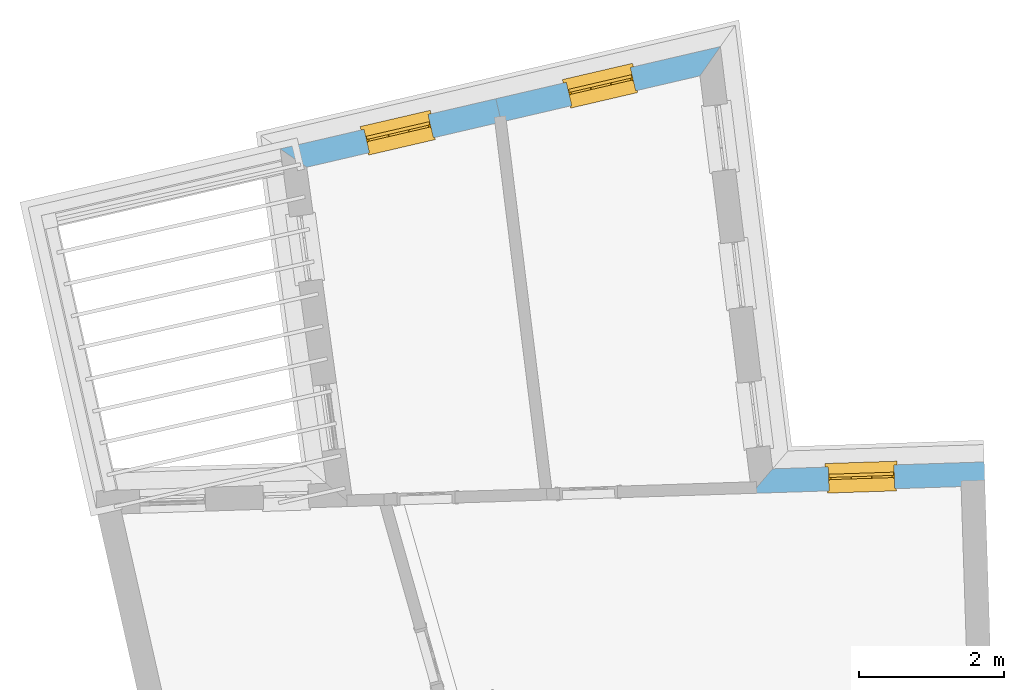
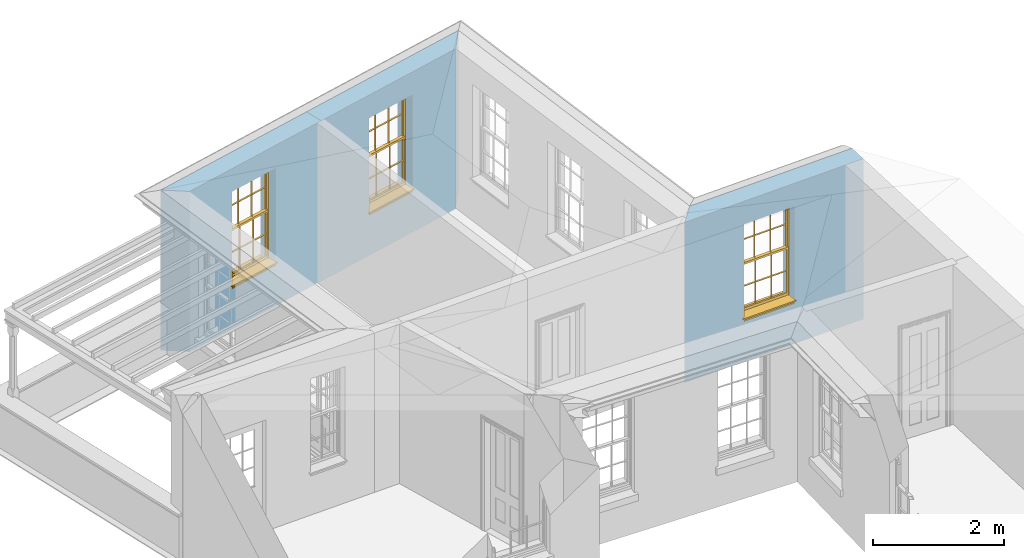
# One storey, part 8 of 11: 3 windows, 3 openings, plus 3 elements that do not belong to this part.
"""IFC2X3 building model written with IfcOpenShell, lengths in metres."""

import ifcopenshell
import ifcopenshell.guid

model = None  # the IFC model being written
_history = None  # IfcOwnerHistory: only IFC2X3 demands one
_inside = {}  # id of a spatial element -> (the spatial element, [elements in it])
_under = {}  # id of a project, library or spatial element -> (it, [spatial elements below it])
_declared = {}  # id of a project -> (the project, [libraries it declares])
_typed = {}  # id of a type object -> (the type object, [elements of that type])
_made_of = {}  # id of a material, layer set ... -> (it, [elements and type objects made of it])


def new_model(schema):
    """Start an empty IFC model of exactly this schema.

    Asked for "IFC4X3", IfcOpenShell would pick the latest addendum, in which some entities
    have other attributes; the version numbers below select the first issue.
    IFC2X3 requires an IfcOwnerHistory on every rooted entity: one is made here for all.
    """
    global model, _history
    if schema == "IFC4X3":
        model = ifcopenshell.file(schema_version=(4, 3, 0, 0))
    else:
        model = ifcopenshell.file(schema=schema)
    _inside.clear()
    _under.clear()
    _declared.clear()
    _typed.clear()
    _made_of.clear()
    _history = None
    if model.schema == "IFC2X3":
        org = make("IfcOrganization", Name="unknown")
        user = make(
            "IfcPersonAndOrganization",
            ThePerson=make("IfcPerson", FamilyName="unknown"),
            TheOrganization=org,
        )
        app = make(
            "IfcApplication",
            ApplicationDeveloper=org,
            Version="unknown",
            ApplicationFullName="unknown",
            ApplicationIdentifier="unknown",
        )
        _history = make(
            "IfcOwnerHistory",
            OwningUser=user,
            OwningApplication=app,
            ChangeAction="ADDED",
            CreationDate=0,
        )
    return model


def make(cls, **values):
    """One entity of the class cls with the attributes given. An attribute that is None is left unset."""
    return model.create_entity(
        cls, **{name: value for name, value in values.items() if value is not None}
    )


def rooted(cls, **values):
    """An entity with a GlobalId (a new one), such as an element, a storey or a relation."""
    return make(cls, GlobalId=ifcopenshell.guid.new(), OwnerHistory=_history, **values)


def si_unit(unit_type, name, prefix=None):
    """IfcSIUnit, for example si_unit("LENGTHUNIT", "METRE", prefix="MILLI")."""
    return make("IfcSIUnit", UnitType=unit_type, Prefix=prefix, Name=name)


def assignment(units):
    """IfcUnitAssignment: the units of a project."""
    return None if units is None else make("IfcUnitAssignment", Units=units)


def point(xyz):
    """IfcCartesianPoint."""
    return None if xyz is None else make("IfcCartesianPoint", Coordinates=xyz)


def direction(xyz):
    """IfcDirection."""
    return None if xyz is None else make("IfcDirection", DirectionRatios=xyz)


def frame(location, z_axis=None, x_axis=None):
    """IfcAxis2Placement3D, a coordinate frame: its origin and axes. An axis left out is left unset."""
    return make(
        "IfcAxis2Placement3D",
        Location=point(location),
        Axis=direction(z_axis),
        RefDirection=direction(x_axis),
    )


def origin():
    """The frame at (0, 0, 0) with its axes left unset."""
    return frame((0.0, 0.0, 0.0))


def place(relative_to, where):
    """IfcLocalPlacement: puts the frame where relative to a parent placement (None: the world)."""
    return make(
        "IfcLocalPlacement", PlacementRelTo=relative_to, RelativePlacement=where
    )


def context(
    kind, dimensions, precision=None, world=None, true_north=None, identifier=None
):
    """IfcGeometricRepresentationContext, for example the 3D "Model" context."""
    return make(
        "IfcGeometricRepresentationContext",
        ContextIdentifier=identifier,
        ContextType=kind,
        CoordinateSpaceDimension=dimensions,
        Precision=precision,
        WorldCoordinateSystem=world,
        TrueNorth=true_north,
    )


def subcontext(parent, identifier, kind, view, scale=None):
    """IfcGeometricRepresentationSubContext, for example "Body" below "Model"."""
    return make(
        "IfcGeometricRepresentationSubContext",
        ContextIdentifier=identifier,
        ContextType=kind,
        ParentContext=parent,
        TargetScale=scale,
        TargetView=view,
    )


def project(units=None, contexts=None):
    """IfcProject with its units and contexts."""
    return rooted(
        "IfcProject",
        Name="project",
        RepresentationContexts=contexts,
        UnitsInContext=assignment(units),
    )


def spatial(cls, under=None, at=None, **own):
    """A site, building, storey or space (cls), placed at a placement, below another one or the project."""
    s = rooted(cls, ObjectPlacement=at, **own)
    if under is not None:
        _under.setdefault(under.id(), (under, []))[1].append(s)
    return s


def polyline(points):
    """IfcPolyline through the points."""
    return make("IfcPolyline", Points=[point(p) for p in points])


def outline(outer, holes=None, kind="AREA"):
    """IfcArbitraryClosedProfileDef: a profile drawn as a closed curve; with holes, ...WithVoids."""
    if holes is None:
        return make("IfcArbitraryClosedProfileDef", ProfileType=kind, OuterCurve=outer)
    return make(
        "IfcArbitraryProfileDefWithVoids",
        ProfileType=kind,
        OuterCurve=outer,
        InnerCurves=holes,
    )


def extrude(swept, where, along, depth):
    """IfcExtrudedAreaSolid: the profile swept, set in the frame where, extruded along a direction by depth."""
    return make(
        "IfcExtrudedAreaSolid",
        SweptArea=swept,
        Position=where,
        ExtrudedDirection=direction(along),
        Depth=depth,
    )


def faces_of(points, faces, orient=None, outer=None):
    """IfcFace entities. A face is a list of loops; a loop is a list of indices into points, from 0.

    orient and outer hold one flag for each loop. By default every Orientation is true, the
    first loop of a face is its IfcFaceOuterBound and the others are IfcFaceBound.
    """
    made = []
    for i, loops in enumerate(faces):
        bounds = []
        for j, loop in enumerate(loops):
            is_outer = j == 0 if outer is None else outer[i][j]
            bounds.append(
                make(
                    "IfcFaceOuterBound" if is_outer else "IfcFaceBound",
                    Bound=make("IfcPolyLoop", Polygon=[points[k] for k in loop]),
                    Orientation=True if orient is None else orient[i][j],
                )
            )
        made.append(make("IfcFace", Bounds=bounds))
    return made


def faceted_brep(points, faces, orient=None, outer=None, voids=None):
    """IfcFacetedBrep: a solid bounded by flat faces; with voids (closed shells), ...WithVoids."""
    shared = [point(p) for p in points]
    hull = make("IfcClosedShell", CfsFaces=faces_of(shared, faces, orient, outer))
    if voids is None:
        return make("IfcFacetedBrep", Outer=hull)
    return make(
        "IfcFacetedBrepWithVoids",
        Outer=hull,
        Voids=[
            make(cls, CfsFaces=faces_of(shared, fs, o, b)) for cls, fs, o, b in voids
        ],
    )


def shape(context_of_items, identifier, shape_type, items):
    """IfcShapeRepresentation: the items that make up one representation, for example the "Body"."""
    return make(
        "IfcShapeRepresentation",
        ContextOfItems=context_of_items,
        RepresentationIdentifier=identifier,
        RepresentationType=shape_type,
        Items=items,
    )


def material(Name=None, Category=None):
    """IfcMaterial."""
    return make("IfcMaterial", Name=Name, Category=Category)


def layer(
    of_material, thickness, ventilated=None, Name=None, Category=None, Priority=None
):
    """IfcMaterialLayer: one layer of a wall or slab, of a material (None: an air gap)."""
    return make(
        "IfcMaterialLayer",
        Material=of_material,
        LayerThickness=thickness,
        IsVentilated=ventilated,
        Name=Name,
        Category=Category,
        Priority=Priority,
    )


def layer_set(layers, Name=None):
    """IfcMaterialLayerSet."""
    return make("IfcMaterialLayerSet", MaterialLayers=layers, LayerSetName=Name)


def layer_usage(for_layer_set, set_direction, sense, offset, extent=None):
    """IfcMaterialLayerSetUsage: how a layer set lies in its element."""
    return make(
        "IfcMaterialLayerSetUsage",
        ForLayerSet=for_layer_set,
        LayerSetDirection=set_direction,
        DirectionSense=sense,
        OffsetFromReferenceLine=offset,
        ReferenceExtent=extent,
    )


def made_of(thing, what):
    """Note that an element or type object is made of a material, layer set ...; save() writes the relation."""
    if what is not None:
        _made_of.setdefault(what.id(), (what, []))[1].append(thing)
    return thing


def element(
    cls,
    number,
    at=None,
    inside=None,
    cuts=None,
    type_object=None,
    material=None,
    context=None,
    identifier="Body",
    shape_type=None,
    held_by="IfcProductDefinitionShape",
    body=None,
    shapes=None,
    **own,
):
    """One element of the class cls, such as IfcWall. Its Tag is "e" and its number.

    at: its placement. inside: the storey or other place that contains it. cuts: it is an
    opening in that element (IfcRelVoidsElement). A single representation is given by context,
    identifier, shape_type and body (its items); several are given by shapes. held_by: the class
    of the entity that holds the representations. save() writes the other relations.
    """
    e = rooted(cls, Tag="e%d" % number, ObjectPlacement=at, **own)
    if body is not None:
        shapes = [shape(context, identifier, shape_type, body)]
    if shapes is not None:
        e.Representation = make(held_by, Representations=shapes)
    if inside is not None:
        _inside.setdefault(inside.id(), (inside, []))[1].append(e)
    if cuts is not None:
        rooted(
            "IfcRelVoidsElement", RelatingBuildingElement=cuts, RelatedOpeningElement=e
        )
    if type_object is not None:
        _typed.setdefault(type_object.id(), (type_object, []))[1].append(e)
    return made_of(e, material)


def fill(opening, filler):
    """IfcRelFillsElement: the door or window that sits in an opening."""
    return rooted(
        "IfcRelFillsElement",
        RelatingOpeningElement=opening,
        RelatedBuildingElement=filler,
    )


def aggregate(whole, parts):
    """IfcRelAggregates: a whole, such as a stair, and the parts it consists of."""
    return rooted("IfcRelAggregates", RelatingObject=whole, RelatedObjects=parts)


def save(model, path):
    """Write the relations noted so far, then the file.

    IfcRelAggregates (storeys below a building ...), IfcRelContainedInSpatialStructure (elements
    in a storey), IfcRelDefinesByType, IfcRelAssociatesMaterial and IfcRelDeclares: one each for
    every whole, place, type object, material and project.
    """
    for whole, parts in _under.values():
        aggregate(whole, parts)
    for where, things in _inside.values():
        rooted(
            "IfcRelContainedInSpatialStructure",
            RelatedElements=things,
            RelatingStructure=where,
        )
    for kind, things in _typed.values():
        rooted("IfcRelDefinesByType", RelatedObjects=things, RelatingType=kind)
    for what, things in _made_of.values():
        rooted("IfcRelAssociatesMaterial", RelatedObjects=things, RelatingMaterial=what)
    for by, libraries in _declared.values():
        rooted("IfcRelDeclares", RelatingContext=by, RelatedDefinitions=libraries)
    model.write(path)


model = new_model("IFC2X3")

# Units and contexts
model_context = context("Model", 3, world=origin())
body_context = subcontext(model_context, "Body", "Model", "MODEL_VIEW")
ifc_project = project(units=[si_unit("PLANEANGLEUNIT", "RADIAN"), si_unit("MASSUNIT", "GRAM", prefix="KILO"), si_unit("FORCEUNIT", "NEWTON", prefix="KILO"), si_unit("LENGTHUNIT", "METRE")], contexts=[model_context])

# Site, building, storey
site_placement = place(None, origin())
site = spatial("IfcSite", under=ifc_project, at=site_placement, CompositionType="ELEMENT")
building_placement = place(None, origin())
building = spatial("IfcBuilding", under=site, at=building_placement, Name="Building plot-10", CompositionType="ELEMENT")
storey_placement = place(None, frame((0.0, 0.0, 4.6)))
storey = spatial("IfcBuildingStorey", under=building, at=storey_placement, Name="Floor 1", CompositionType="ELEMENT", Elevation=4.6)

# Wall, opening, window
ifc_material = material(Name="Masonry")
ifc_layer = layer(ifc_material, 0.33, ventilated=False)
ifc_layer_set = layer_set([ifc_layer], Name="My Wall")
ifc_layer_usage = layer_usage(ifc_layer_set, "AXIS2", "NEGATIVE", 0.08)
wall_1_placement = place(storey_placement, origin())
wall_1 = element("IfcWallStandardCase", 1, at=wall_1_placement, inside=storey, material=ifc_layer_usage, Name="exterior", context=body_context, shape_type="SweptSolid", body=[
    extrude(outline(polyline([(53.7197932357243, 20.1894345087971), (53.7090479718279, 20.5192595219538), (50.7843534970595, 20.4239768335759), (50.4938484504191, 20.0843374826447), (53.7197932357243, 20.1894345087971)])), origin(), (0.0, 0.0, 1.0), 3.0),
])
opening_1_placement = place(storey_placement, frame((0.0, 0.0, 0.75)))
opening_1 = element("IfcOpeningElement", 2, at=opening_1_placement, cuts=wall_1, Name="Opening", ObjectType="Opening", context=body_context, shape_type="SweptSolid", body=[
    extrude(outline(polyline([(52.4624157814879, 20.478645889474), (51.552898320965, 20.4490150102444), (51.5636435848614, 20.1191899970877), (52.4731610453844, 20.1488208763173), (52.4624157814879, 20.478645889474)])), origin(), (0.0, 0.0, 1.0), 1.82),
])
window_1_placement = place(storey_placement, frame((52.4705561329246, 20.2287784552644, 0.75), z_axis=(0.0, 0.0, 1.0), x_axis=(-0.909517460522927, -0.0296308792295648, 0.0)))
window_1 = element("IfcWindow", 3, at=window_1_placement, inside=storey, Name="circulation outside window", OverallHeight=1.82, OverallWidth=0.91, context=body_context, shape_type="Brep", held_by="IfcProductRepresentation", body=[
    faceted_brep([(0.033125, -0.105, 0.975209), (0.01, -0.105, 0.975209), (0.033125, -0.105, 1.376042), (0.876875, -0.105, 0.975209), (0.876875, -0.105, 1.376042), (0.9, -0.105, 0.975209), (0.876875, -0.105, 1.386042), (0.876875, -0.105, 1.786875), (0.9, -0.105, 1.81), (0.033125, -0.105, 1.786875), (0.033125, -0.105, 1.386042), (0.01, -0.105, 1.81), (0.876875, -0.135, 1.376042), (0.876875, -0.135, 0.975209), (0.9, -0.135, 0.937083), (0.033125, -0.135, 1.786875), (0.01, -0.135, 1.81), (0.033125, -0.135, 1.386042), (0.01, -0.135, 0.937083), (0.033125, -0.135, 0.975209), (0.033125, -0.135, 1.376042), (0.876875, -0.135, 1.786875), (0.876875, -0.135, 1.386042), (0.9, -0.135, 1.81), (0.033125, -0.105, 0.937083), (0.01, -0.105, 0.937083), (0.033125, -0.105, 0.53625), (0.876875, -0.105, 0.937083), (0.876875, -0.105, 0.53625), (0.9, -0.105, 0.937083), (0.876875, -0.105, 0.52625), (0.876875, -0.105, 0.125417), (0.9, -0.105, 0.077167), (0.033125, -0.105, 0.125417), (0.033125, -0.105, 0.52625), (0.01, -0.105, 0.077167), (-0.0425, -0.25, 0.01), (-0.0425, -0.3, 0.001667), (0.0, -0.25, 0.01), (0.9525, -0.25, 0.01), (0.91, -0.25, 0.01), (0.9525, -0.3, 0.001667), (-0.02, 0.08, 0.077167), (0.0, 0.08, 0.077167), (-0.02, 0.11, 0.077167), (0.0, -0.06, 0.077167), (0.01, -0.06, 0.077167), (0.91, -0.06, 0.077167), (0.91, 0.08, 0.077167), (0.9, -0.06, 0.077167), (0.93, 0.08, 0.077167), (0.93, 0.11, 0.077167), (0.01, -0.075, 0.975209), (0.9, -0.075, 0.975209), (0.876875, -0.075, 0.125417), (0.876875, -0.075, 0.52625), (0.9, -0.075, 0.077167), (0.876875, -0.075, 0.53625), (0.876875, -0.075, 0.937083), (0.033125, -0.075, 0.125417), (0.01, -0.075, 0.077167), (0.033125, -0.075, 0.52625), (0.033125, -0.075, 0.937083), (0.033125, -0.075, 0.53625), (-0.02, 0.08, 0.052167), (-0.02, 0.11, 0.052167), (0.93, 0.11, 0.052167), (0.93, 0.08, 0.052167), (0.91, 0.08, 0.052167), (0.0, 0.08, 0.052167), (0.91, -0.15, 0.026667), (0.0, -0.15, 0.026667), (-0.0425, -0.3, -0.123333), (0.9525, -0.3, -0.123333), (-0.0425, -0.25, -0.123333), (0.9525, -0.25, -0.123333), (0.01, -0.06, 1.81), (0.9, -0.06, 1.81), (0.0, -0.06, 1.82), (0.91, -0.06, 1.82), (0.01, -0.15, 0.077167), (0.9, -0.15, 0.077167), (0.592292, -0.105, 0.125417), (0.592292, -0.075, 0.125417), (0.317708, -0.075, 0.125417), (0.317708, -0.105, 0.125417), (0.592292, -0.105, 0.53625), (0.317708, -0.105, 0.53625), (0.317708, -0.105, 0.52625), (0.592292, -0.105, 0.52625), (0.592292, -0.075, 0.53625), (0.317708, -0.075, 0.53625), (0.592292, -0.135, 1.386042), (0.592292, -0.105, 1.386042), (0.317708, -0.105, 1.386042), (0.317708, -0.135, 1.386042), (0.317708, -0.135, 1.376042), (0.592292, -0.135, 1.376042), (0.317708, -0.105, 1.376042), (0.592292, -0.105, 1.376042), (0.602292, -0.135, 1.376042), (0.592292, -0.135, 0.975209), (0.602292, -0.135, 0.975209), (0.602292, -0.105, 0.975209), (0.592292, -0.105, 0.975209), (0.602292, -0.105, 1.376042), (0.602292, -0.075, 0.53625), (0.602292, -0.105, 0.53625), (0.317708, -0.075, 0.52625), (0.307708, -0.075, 0.125417), (0.307708, -0.075, 0.52625), (0.602292, -0.075, 0.52625), (0.602292, -0.075, 0.125417), (0.592292, -0.075, 0.52625), (0.307708, -0.075, 0.53625), (0.317708, -0.075, 0.937083), (0.307708, -0.075, 0.937083), (0.602292, -0.075, 0.937083), (0.592292, -0.075, 0.937083), (0.307708, -0.105, 0.52625), (0.307708, -0.105, 0.125417), (0.307708, -0.105, 0.53625), (0.307708, -0.105, 0.937083), (0.592292, -0.105, 0.937083), (0.317708, -0.105, 0.937083), (0.602292, -0.105, 0.937083), (0.602292, -0.105, 0.52625), (0.602292, -0.105, 0.125417), (0.307708, -0.135, 1.386042), (0.307708, -0.135, 1.376042), (0.307708, -0.135, 0.975209), (0.317708, -0.135, 0.975209), (0.317708, -0.135, 1.786875), (0.307708, -0.135, 1.786875), (0.602292, -0.135, 1.786875), (0.592292, -0.135, 1.786875), (0.602292, -0.135, 1.386042), (0.602292, -0.105, 1.386042), (0.307708, -0.105, 1.386042), (0.307708, -0.105, 1.786875), (0.317708, -0.105, 1.786875), (0.592292, -0.105, 1.786875), (0.602292, -0.105, 1.786875), (0.307708, -0.105, 1.376042), (0.317708, -0.105, 0.975209), (0.307708, -0.105, 0.975209), (0.91, -0.15, 1.82), (0.9, -0.15, 1.81), (0.01, -0.15, 1.81), (0.0, -0.15, 1.82), (0.91, -0.25, 0.0), (0.0, -0.25, 0.0), (0.91, 0.08, 0.0), (0.0, 0.08, 0.0)], [[[0, 1, 2]], [[3, 4, 5]], [[6, 7, 8]], [[9, 10, 11]], [[12, 13, 14]], [[15, 16, 17]], [[18, 19, 20]], [[21, 22, 23]], [[24, 25, 26]], [[27, 28, 29]], [[30, 31, 32]], [[33, 34, 35]], [[14, 27, 29]], [[25, 24, 18]], [[36, 37, 38]], [[39, 40, 41]], [[42, 43, 44]], [[45, 46, 43]], [[47, 48, 49]], [[50, 51, 48]], [[1, 0, 52]], [[5, 53, 3]], [[54, 55, 56]], [[57, 58, 53]], [[59, 60, 61]], [[62, 63, 52]], [[48, 43, 46, 49]], [[51, 44, 43, 48]], [[64, 42, 44, 65]], [[65, 44, 51, 66]], [[66, 51, 50, 67]], [[65, 66, 68, 69]], [[60, 56, 49, 46]], [[70, 71, 38, 40]], [[37, 41, 40, 38]], [[37, 72, 73, 41]], [[74, 75, 73, 72]], [[8, 11, 76, 77]], [[76, 78, 79, 77]], [[32, 35, 80, 81]], [[81, 80, 71, 70]], [[82, 83, 84, 85]], [[86, 87, 88, 89]], [[86, 90, 91, 87]], [[92, 93, 94, 95]], [[92, 95, 96, 97]], [[96, 98, 99, 97]], [[100, 97, 101, 102]], [[103, 104, 99, 105]], [[97, 99, 104, 101]], [[102, 103, 105, 100]], [[28, 57, 106, 107]], [[108, 84, 109, 110]], [[111, 112, 83, 113]], [[114, 110, 61, 63]], [[90, 113, 108, 91]], [[115, 91, 114, 116]], [[117, 106, 90, 118]], [[111, 106, 57, 55]], [[119, 110, 109, 120]], [[34, 61, 110, 119]], [[89, 113, 83, 82]], [[88, 108, 113, 89]], [[85, 84, 108, 88]], [[121, 114, 63, 26]], [[122, 116, 114, 121]], [[123, 118, 90, 86]], [[87, 91, 115, 124]], [[107, 106, 117, 125]], [[126, 111, 55, 30]], [[127, 112, 111, 126]], [[126, 30, 28, 107]], [[88, 119, 120, 85]], [[126, 89, 82, 127]], [[125, 123, 86, 107]], [[121, 26, 34, 119]], [[124, 122, 121, 87]], [[128, 17, 20, 129]], [[96, 129, 130, 131]], [[132, 133, 128, 95]], [[134, 135, 92, 136]], [[100, 12, 22, 136]], [[137, 6, 4, 105]], [[94, 138, 139, 140]], [[137, 93, 141, 142]], [[99, 98, 94, 93]], [[143, 2, 10, 138]], [[144, 145, 143, 98]], [[129, 143, 145, 130]], [[20, 2, 143, 129]], [[131, 144, 98, 96]], [[128, 138, 10, 17]], [[133, 139, 138, 128]], [[135, 141, 93, 92]], [[95, 94, 140, 132]], [[22, 6, 137, 136]], [[136, 137, 142, 134]], [[100, 105, 4, 12]], [[107, 86, 89, 126]], [[106, 111, 113, 90]], [[91, 108, 110, 114]], [[87, 121, 119, 88]], [[97, 100, 136, 92]], [[129, 96, 95, 128]], [[98, 143, 138, 94]], [[105, 99, 93, 137]], [[131, 101, 104, 144]], [[124, 115, 118, 123]], [[132, 140, 141, 135]], [[120, 109, 59, 33]], [[15, 9, 139, 133]], [[134, 142, 7, 21]], [[31, 54, 112, 127]], [[36, 74, 72, 37]], [[39, 41, 73, 75]], [[18, 14, 101, 131]], [[23, 16, 132, 135]], [[83, 56, 60, 84]], [[52, 53, 118, 115]], [[53, 52, 144, 104]], [[11, 8, 141, 140]], [[14, 18, 124, 123]], [[2, 1, 11, 10]], [[8, 5, 4, 6]], [[57, 53, 56, 55]], [[60, 52, 63, 61]], [[26, 25, 35, 34]], [[32, 29, 28, 30]], [[14, 23, 22, 12]], [[18, 20, 17, 16]], [[19, 0, 2, 20]], [[17, 10, 9, 15]], [[12, 4, 3, 13]], [[21, 7, 6, 22]], [[27, 58, 57, 28]], [[30, 55, 54, 31]], [[33, 59, 61, 34]], [[26, 63, 62, 24]], [[5, 8, 77, 53]], [[76, 11, 1, 52]], [[46, 45, 78, 76]], [[49, 77, 79, 47]], [[70, 146, 147, 81]], [[71, 80, 148, 149]], [[19, 130, 145, 0]], [[102, 13, 3, 103]], [[116, 122, 24, 62]], [[29, 32, 81, 14]], [[80, 35, 25, 18]], [[60, 46, 76, 52]], [[77, 49, 56, 53]], [[23, 14, 81, 147]], [[16, 148, 80, 18]], [[35, 85, 120]], [[120, 33, 35]], [[127, 82, 32]], [[32, 31, 127]], [[32, 82, 85, 35]], [[102, 101, 14]], [[14, 13, 102]], [[18, 131, 130]], [[130, 19, 18]], [[134, 21, 23]], [[23, 135, 134]], [[16, 15, 133]], [[133, 132, 16]], [[11, 140, 139]], [[139, 9, 11]], [[142, 141, 8]], [[8, 7, 142]], [[23, 147, 148, 16]], [[146, 149, 148, 147]], [[52, 115, 116]], [[116, 62, 52]], [[118, 53, 117]], [[58, 117, 53]], [[27, 125, 117, 58]], [[56, 83, 112]], [[112, 54, 56]], [[109, 84, 60]], [[60, 59, 109]], [[125, 27, 14]], [[14, 123, 125]], [[122, 124, 18]], [[18, 24, 122]], [[145, 144, 52]], [[52, 0, 145]], [[103, 3, 53]], [[53, 104, 103]], [[79, 78, 149, 146]], [[78, 45, 71, 149]], [[146, 70, 47, 79]], [[150, 75, 74, 151]], [[68, 66, 67]], [[48, 68, 67, 50]], [[69, 64, 65]], [[42, 64, 69, 43]], [[69, 68, 152, 153]], [[70, 68, 48, 47]], [[150, 152, 68, 70]], [[43, 69, 71, 45]], [[69, 153, 151, 71]], [[152, 150, 151, 153]], [[38, 151, 74, 36]], [[71, 151, 38]], [[39, 75, 150, 40]], [[40, 150, 70]]]),
])
fill(opening_1, window_1)

wall_2_placement = place(storey_placement, origin())
wall_2 = element("IfcWallStandardCase", 4, at=wall_2_placement, inside=storey, material=ifc_layer_usage, Name="exterior", context=body_context, shape_type="SweptSolid", body=[
    extrude(outline(polyline([(49.7798970152204, 25.8564795072323), (50.0623886340856, 26.2609056783057), (46.9584811499292, 25.5397253538022), (47.0331658946155, 25.2182876632444), (49.7798970152204, 25.8564795072323)])), origin(), (0.0, 0.0, 1.0), 3.0),
])
opening_2_placement = place(storey_placement, frame((0.0, 0.0, 0.75)))
opening_2 = element("IfcOpeningElement", 5, at=opening_2_placement, cuts=wall_2, Name="Opening", ObjectType="Opening", context=body_context, shape_type="SweptSolid", body=[
    extrude(outline(polyline([(48.8183352064313, 25.9718549062595), (47.9319464233779, 25.7659060648518), (48.0066311680642, 25.444468374294), (48.8930199511176, 25.6504172157017), (48.8183352064313, 25.9718549062595)])), origin(), (0.0, 0.0, 1.0), 1.82),
])
window_2_placement = place(storey_placement, frame((48.8749145584663, 25.7283415043217, 0.75), z_axis=(0.0, 0.0, 1.0), x_axis=(-0.886388783053363, -0.205948841407682, 0.0)))
window_2 = element("IfcWindow", 6, at=window_2_placement, inside=storey, Name="bedroom outside window", OverallHeight=1.82, OverallWidth=0.91, context=body_context, shape_type="Brep", held_by="IfcProductRepresentation", body=[
    faceted_brep([(0.033125, -0.105, 0.975209), (0.01, -0.105, 0.975209), (0.033125, -0.105, 1.376042), (0.876875, -0.105, 0.975209), (0.876875, -0.105, 1.376042), (0.9, -0.105, 0.975209), (0.876875, -0.105, 1.386042), (0.876875, -0.105, 1.786875), (0.9, -0.105, 1.81), (0.033125, -0.105, 1.786875), (0.033125, -0.105, 1.386042), (0.01, -0.105, 1.81), (0.876875, -0.135, 1.376042), (0.876875, -0.135, 0.975209), (0.9, -0.135, 0.937083), (0.033125, -0.135, 1.786875), (0.01, -0.135, 1.81), (0.033125, -0.135, 1.386042), (0.01, -0.135, 0.937083), (0.033125, -0.135, 0.975209), (0.033125, -0.135, 1.376042), (0.876875, -0.135, 1.786875), (0.876875, -0.135, 1.386042), (0.9, -0.135, 1.81), (0.033125, -0.105, 0.937083), (0.01, -0.105, 0.937083), (0.033125, -0.105, 0.53625), (0.876875, -0.105, 0.937083), (0.876875, -0.105, 0.53625), (0.9, -0.105, 0.937083), (0.876875, -0.105, 0.52625), (0.876875, -0.105, 0.125417), (0.9, -0.105, 0.077167), (0.033125, -0.105, 0.125417), (0.033125, -0.105, 0.52625), (0.01, -0.105, 0.077167), (-0.0425, -0.25, 0.01), (-0.0425, -0.3, 0.001667), (0.0, -0.25, 0.01), (0.9525, -0.25, 0.01), (0.91, -0.25, 0.01), (0.9525, -0.3, 0.001667), (-0.02, 0.08, 0.077167), (0.0, 0.08, 0.077167), (-0.02, 0.11, 0.077167), (0.0, -0.06, 0.077167), (0.01, -0.06, 0.077167), (0.91, -0.06, 0.077167), (0.91, 0.08, 0.077167), (0.9, -0.06, 0.077167), (0.93, 0.08, 0.077167), (0.93, 0.11, 0.077167), (0.01, -0.075, 0.975209), (0.9, -0.075, 0.975209), (0.876875, -0.075, 0.125417), (0.876875, -0.075, 0.52625), (0.9, -0.075, 0.077167), (0.876875, -0.075, 0.53625), (0.876875, -0.075, 0.937083), (0.033125, -0.075, 0.125417), (0.01, -0.075, 0.077167), (0.033125, -0.075, 0.52625), (0.033125, -0.075, 0.937083), (0.033125, -0.075, 0.53625), (-0.02, 0.08, 0.052167), (-0.02, 0.11, 0.052167), (0.93, 0.11, 0.052167), (0.93, 0.08, 0.052167), (0.91, 0.08, 0.052167), (0.0, 0.08, 0.052167), (0.91, -0.15, 0.026667), (0.0, -0.15, 0.026667), (-0.0425, -0.3, -0.123333), (0.9525, -0.3, -0.123333), (-0.0425, -0.25, -0.123333), (0.9525, -0.25, -0.123333), (0.01, -0.06, 1.81), (0.9, -0.06, 1.81), (0.0, -0.06, 1.82), (0.91, -0.06, 1.82), (0.01, -0.15, 0.077167), (0.9, -0.15, 0.077167), (0.592292, -0.105, 0.125417), (0.592292, -0.075, 0.125417), (0.317708, -0.075, 0.125417), (0.317708, -0.105, 0.125417), (0.592292, -0.105, 0.53625), (0.317708, -0.105, 0.53625), (0.317708, -0.105, 0.52625), (0.592292, -0.105, 0.52625), (0.592292, -0.075, 0.53625), (0.317708, -0.075, 0.53625), (0.592292, -0.135, 1.386042), (0.592292, -0.105, 1.386042), (0.317708, -0.105, 1.386042), (0.317708, -0.135, 1.386042), (0.317708, -0.135, 1.376042), (0.592292, -0.135, 1.376042), (0.317708, -0.105, 1.376042), (0.592292, -0.105, 1.376042), (0.602292, -0.135, 1.376042), (0.592292, -0.135, 0.975209), (0.602292, -0.135, 0.975209), (0.602292, -0.105, 0.975209), (0.592292, -0.105, 0.975209), (0.602292, -0.105, 1.376042), (0.602292, -0.075, 0.53625), (0.602292, -0.105, 0.53625), (0.317708, -0.075, 0.52625), (0.307708, -0.075, 0.125417), (0.307708, -0.075, 0.52625), (0.602292, -0.075, 0.52625), (0.602292, -0.075, 0.125417), (0.592292, -0.075, 0.52625), (0.307708, -0.075, 0.53625), (0.317708, -0.075, 0.937083), (0.307708, -0.075, 0.937083), (0.602292, -0.075, 0.937083), (0.592292, -0.075, 0.937083), (0.307708, -0.105, 0.52625), (0.307708, -0.105, 0.125417), (0.307708, -0.105, 0.53625), (0.307708, -0.105, 0.937083), (0.592292, -0.105, 0.937083), (0.317708, -0.105, 0.937083), (0.602292, -0.105, 0.937083), (0.602292, -0.105, 0.52625), (0.602292, -0.105, 0.125417), (0.307708, -0.135, 1.386042), (0.307708, -0.135, 1.376042), (0.307708, -0.135, 0.975209), (0.317708, -0.135, 0.975209), (0.317708, -0.135, 1.786875), (0.307708, -0.135, 1.786875), (0.602292, -0.135, 1.786875), (0.592292, -0.135, 1.786875), (0.602292, -0.135, 1.386042), (0.602292, -0.105, 1.386042), (0.307708, -0.105, 1.386042), (0.307708, -0.105, 1.786875), (0.317708, -0.105, 1.786875), (0.592292, -0.105, 1.786875), (0.602292, -0.105, 1.786875), (0.307708, -0.105, 1.376042), (0.317708, -0.105, 0.975209), (0.307708, -0.105, 0.975209), (0.91, -0.15, 1.82), (0.9, -0.15, 1.81), (0.01, -0.15, 1.81), (0.0, -0.15, 1.82), (0.91, -0.25, 0.0), (0.0, -0.25, 0.0), (0.91, 0.08, 0.0), (0.0, 0.08, 0.0)], [[[0, 1, 2]], [[3, 4, 5]], [[6, 7, 8]], [[9, 10, 11]], [[12, 13, 14]], [[15, 16, 17]], [[18, 19, 20]], [[21, 22, 23]], [[24, 25, 26]], [[27, 28, 29]], [[30, 31, 32]], [[33, 34, 35]], [[14, 27, 29]], [[25, 24, 18]], [[36, 37, 38]], [[39, 40, 41]], [[42, 43, 44]], [[45, 46, 43]], [[47, 48, 49]], [[50, 51, 48]], [[1, 0, 52]], [[5, 53, 3]], [[54, 55, 56]], [[57, 58, 53]], [[59, 60, 61]], [[62, 63, 52]], [[48, 43, 46, 49]], [[51, 44, 43, 48]], [[64, 42, 44, 65]], [[65, 44, 51, 66]], [[66, 51, 50, 67]], [[65, 66, 68, 69]], [[60, 56, 49, 46]], [[70, 71, 38, 40]], [[37, 41, 40, 38]], [[37, 72, 73, 41]], [[74, 75, 73, 72]], [[8, 11, 76, 77]], [[76, 78, 79, 77]], [[32, 35, 80, 81]], [[81, 80, 71, 70]], [[82, 83, 84, 85]], [[86, 87, 88, 89]], [[86, 90, 91, 87]], [[92, 93, 94, 95]], [[92, 95, 96, 97]], [[96, 98, 99, 97]], [[100, 97, 101, 102]], [[103, 104, 99, 105]], [[97, 99, 104, 101]], [[102, 103, 105, 100]], [[28, 57, 106, 107]], [[108, 84, 109, 110]], [[111, 112, 83, 113]], [[114, 110, 61, 63]], [[90, 113, 108, 91]], [[115, 91, 114, 116]], [[117, 106, 90, 118]], [[111, 106, 57, 55]], [[119, 110, 109, 120]], [[34, 61, 110, 119]], [[89, 113, 83, 82]], [[88, 108, 113, 89]], [[85, 84, 108, 88]], [[121, 114, 63, 26]], [[122, 116, 114, 121]], [[123, 118, 90, 86]], [[87, 91, 115, 124]], [[107, 106, 117, 125]], [[126, 111, 55, 30]], [[127, 112, 111, 126]], [[126, 30, 28, 107]], [[88, 119, 120, 85]], [[126, 89, 82, 127]], [[125, 123, 86, 107]], [[121, 26, 34, 119]], [[124, 122, 121, 87]], [[128, 17, 20, 129]], [[96, 129, 130, 131]], [[132, 133, 128, 95]], [[134, 135, 92, 136]], [[100, 12, 22, 136]], [[137, 6, 4, 105]], [[94, 138, 139, 140]], [[137, 93, 141, 142]], [[99, 98, 94, 93]], [[143, 2, 10, 138]], [[144, 145, 143, 98]], [[129, 143, 145, 130]], [[20, 2, 143, 129]], [[131, 144, 98, 96]], [[128, 138, 10, 17]], [[133, 139, 138, 128]], [[135, 141, 93, 92]], [[95, 94, 140, 132]], [[22, 6, 137, 136]], [[136, 137, 142, 134]], [[100, 105, 4, 12]], [[107, 86, 89, 126]], [[106, 111, 113, 90]], [[91, 108, 110, 114]], [[87, 121, 119, 88]], [[97, 100, 136, 92]], [[129, 96, 95, 128]], [[98, 143, 138, 94]], [[105, 99, 93, 137]], [[131, 101, 104, 144]], [[124, 115, 118, 123]], [[132, 140, 141, 135]], [[120, 109, 59, 33]], [[15, 9, 139, 133]], [[134, 142, 7, 21]], [[31, 54, 112, 127]], [[36, 74, 72, 37]], [[39, 41, 73, 75]], [[18, 14, 101, 131]], [[23, 16, 132, 135]], [[83, 56, 60, 84]], [[52, 53, 118, 115]], [[53, 52, 144, 104]], [[11, 8, 141, 140]], [[14, 18, 124, 123]], [[2, 1, 11, 10]], [[8, 5, 4, 6]], [[57, 53, 56, 55]], [[60, 52, 63, 61]], [[26, 25, 35, 34]], [[32, 29, 28, 30]], [[14, 23, 22, 12]], [[18, 20, 17, 16]], [[19, 0, 2, 20]], [[17, 10, 9, 15]], [[12, 4, 3, 13]], [[21, 7, 6, 22]], [[27, 58, 57, 28]], [[30, 55, 54, 31]], [[33, 59, 61, 34]], [[26, 63, 62, 24]], [[5, 8, 77, 53]], [[76, 11, 1, 52]], [[46, 45, 78, 76]], [[49, 77, 79, 47]], [[70, 146, 147, 81]], [[71, 80, 148, 149]], [[19, 130, 145, 0]], [[102, 13, 3, 103]], [[116, 122, 24, 62]], [[29, 32, 81, 14]], [[80, 35, 25, 18]], [[60, 46, 76, 52]], [[77, 49, 56, 53]], [[23, 14, 81, 147]], [[16, 148, 80, 18]], [[35, 85, 120]], [[120, 33, 35]], [[127, 82, 32]], [[32, 31, 127]], [[32, 82, 85, 35]], [[102, 101, 14]], [[14, 13, 102]], [[18, 131, 130]], [[130, 19, 18]], [[134, 21, 23]], [[23, 135, 134]], [[16, 15, 133]], [[133, 132, 16]], [[11, 140, 139]], [[139, 9, 11]], [[142, 141, 8]], [[8, 7, 142]], [[23, 147, 148, 16]], [[146, 149, 148, 147]], [[52, 115, 116]], [[116, 62, 52]], [[118, 53, 117]], [[58, 117, 53]], [[27, 125, 117, 58]], [[56, 83, 112]], [[112, 54, 56]], [[109, 84, 60]], [[60, 59, 109]], [[125, 27, 14]], [[14, 123, 125]], [[122, 124, 18]], [[18, 24, 122]], [[145, 144, 52]], [[52, 0, 145]], [[103, 3, 53]], [[53, 104, 103]], [[79, 78, 149, 146]], [[78, 45, 71, 149]], [[146, 70, 47, 79]], [[150, 75, 74, 151]], [[68, 66, 67]], [[48, 68, 67, 50]], [[69, 64, 65]], [[42, 64, 69, 43]], [[69, 68, 152, 153]], [[70, 68, 48, 47]], [[150, 152, 68, 70]], [[43, 69, 71, 45]], [[69, 153, 151, 71]], [[152, 150, 151, 153]], [[38, 151, 74, 36]], [[71, 151, 38]], [[39, 75, 150, 40]], [[40, 150, 70]]]),
])
fill(opening_2, window_2)

wall_3_placement = place(storey_placement, origin())
wall_3 = element("IfcWallStandardCase", 7, at=wall_3_placement, inside=storey, material=ifc_layer_usage, Name="exterior", context=body_context, shape_type="SweptSolid", body=[
    extrude(outline(polyline([(47.0331658946155, 25.2182876632444), (46.9584811499292, 25.5397253538022), (43.9765041708865, 24.846875088005), (44.3445319443295, 24.5935944613253), (47.0331658946155, 25.2182876632444)])), origin(), (0.0, 0.0, 1.0), 3.0),
])
opening_3_placement = place(storey_placement, frame((0.0, 0.0, 0.75)))
opening_3 = element("IfcOpeningElement", 8, at=opening_3_placement, cuts=wall_3, Name="Opening", ObjectType="Opening", context=body_context, shape_type="SweptSolid", body=[
    extrude(outline(polyline([(46.0218018355545, 25.3220917112583), (45.1354130525011, 25.1161428698506), (45.2100977971874, 24.7947051792928), (46.0964865802408, 25.0006540207005), (46.0218018355545, 25.3220917112583)])), origin(), (0.0, 0.0, 1.0), 1.82),
])
window_3_placement = place(storey_placement, frame((46.0783811875896, 25.0785783093205, 0.75), z_axis=(0.0, 0.0, 1.0), x_axis=(-0.88638878305337, -0.205948841407682, 0.0)))
window_3 = element("IfcWindow", 9, at=window_3_placement, inside=storey, Name="bedroom outside window", OverallHeight=1.82, OverallWidth=0.91, context=body_context, shape_type="Brep", held_by="IfcProductRepresentation", body=[
    faceted_brep([(0.033125, -0.105, 0.975209), (0.01, -0.105, 0.975209), (0.033125, -0.105, 1.376042), (0.876875, -0.105, 0.975209), (0.876875, -0.105, 1.376042), (0.9, -0.105, 0.975209), (0.876875, -0.105, 1.386042), (0.876875, -0.105, 1.786875), (0.9, -0.105, 1.81), (0.033125, -0.105, 1.786875), (0.033125, -0.105, 1.386042), (0.01, -0.105, 1.81), (0.876875, -0.135, 1.376042), (0.876875, -0.135, 0.975209), (0.9, -0.135, 0.937083), (0.033125, -0.135, 1.786875), (0.01, -0.135, 1.81), (0.033125, -0.135, 1.386042), (0.01, -0.135, 0.937083), (0.033125, -0.135, 0.975209), (0.033125, -0.135, 1.376042), (0.876875, -0.135, 1.786875), (0.876875, -0.135, 1.386042), (0.9, -0.135, 1.81), (0.033125, -0.105, 0.937083), (0.01, -0.105, 0.937083), (0.033125, -0.105, 0.53625), (0.876875, -0.105, 0.937083), (0.876875, -0.105, 0.53625), (0.9, -0.105, 0.937083), (0.876875, -0.105, 0.52625), (0.876875, -0.105, 0.125417), (0.9, -0.105, 0.077167), (0.033125, -0.105, 0.125417), (0.033125, -0.105, 0.52625), (0.01, -0.105, 0.077167), (-0.0425, -0.25, 0.01), (-0.0425, -0.3, 0.001667), (0.0, -0.25, 0.01), (0.9525, -0.25, 0.01), (0.91, -0.25, 0.01), (0.9525, -0.3, 0.001667), (-0.02, 0.08, 0.077167), (0.0, 0.08, 0.077167), (-0.02, 0.11, 0.077167), (0.0, -0.06, 0.077167), (0.01, -0.06, 0.077167), (0.91, -0.06, 0.077167), (0.91, 0.08, 0.077167), (0.9, -0.06, 0.077167), (0.93, 0.08, 0.077167), (0.93, 0.11, 0.077167), (0.01, -0.075, 0.975209), (0.9, -0.075, 0.975209), (0.876875, -0.075, 0.125417), (0.876875, -0.075, 0.52625), (0.9, -0.075, 0.077167), (0.876875, -0.075, 0.53625), (0.876875, -0.075, 0.937083), (0.033125, -0.075, 0.125417), (0.01, -0.075, 0.077167), (0.033125, -0.075, 0.52625), (0.033125, -0.075, 0.937083), (0.033125, -0.075, 0.53625), (-0.02, 0.08, 0.052167), (-0.02, 0.11, 0.052167), (0.93, 0.11, 0.052167), (0.93, 0.08, 0.052167), (0.91, 0.08, 0.052167), (0.0, 0.08, 0.052167), (0.91, -0.15, 0.026667), (0.0, -0.15, 0.026667), (-0.0425, -0.3, -0.123333), (0.9525, -0.3, -0.123333), (-0.0425, -0.25, -0.123333), (0.9525, -0.25, -0.123333), (0.01, -0.06, 1.81), (0.9, -0.06, 1.81), (0.0, -0.06, 1.82), (0.91, -0.06, 1.82), (0.01, -0.15, 0.077167), (0.9, -0.15, 0.077167), (0.592292, -0.105, 0.125417), (0.592292, -0.075, 0.125417), (0.317708, -0.075, 0.125417), (0.317708, -0.105, 0.125417), (0.592292, -0.105, 0.53625), (0.317708, -0.105, 0.53625), (0.317708, -0.105, 0.52625), (0.592292, -0.105, 0.52625), (0.592292, -0.075, 0.53625), (0.317708, -0.075, 0.53625), (0.592292, -0.135, 1.386042), (0.592292, -0.105, 1.386042), (0.317708, -0.105, 1.386042), (0.317708, -0.135, 1.386042), (0.317708, -0.135, 1.376042), (0.592292, -0.135, 1.376042), (0.317708, -0.105, 1.376042), (0.592292, -0.105, 1.376042), (0.602292, -0.135, 1.376042), (0.592292, -0.135, 0.975209), (0.602292, -0.135, 0.975209), (0.602292, -0.105, 0.975209), (0.592292, -0.105, 0.975209), (0.602292, -0.105, 1.376042), (0.602292, -0.075, 0.53625), (0.602292, -0.105, 0.53625), (0.317708, -0.075, 0.52625), (0.307708, -0.075, 0.125417), (0.307708, -0.075, 0.52625), (0.602292, -0.075, 0.52625), (0.602292, -0.075, 0.125417), (0.592292, -0.075, 0.52625), (0.307708, -0.075, 0.53625), (0.317708, -0.075, 0.937083), (0.307708, -0.075, 0.937083), (0.602292, -0.075, 0.937083), (0.592292, -0.075, 0.937083), (0.307708, -0.105, 0.52625), (0.307708, -0.105, 0.125417), (0.307708, -0.105, 0.53625), (0.307708, -0.105, 0.937083), (0.592292, -0.105, 0.937083), (0.317708, -0.105, 0.937083), (0.602292, -0.105, 0.937083), (0.602292, -0.105, 0.52625), (0.602292, -0.105, 0.125417), (0.307708, -0.135, 1.386042), (0.307708, -0.135, 1.376042), (0.307708, -0.135, 0.975209), (0.317708, -0.135, 0.975209), (0.317708, -0.135, 1.786875), (0.307708, -0.135, 1.786875), (0.602292, -0.135, 1.786875), (0.592292, -0.135, 1.786875), (0.602292, -0.135, 1.386042), (0.602292, -0.105, 1.386042), (0.307708, -0.105, 1.386042), (0.307708, -0.105, 1.786875), (0.317708, -0.105, 1.786875), (0.592292, -0.105, 1.786875), (0.602292, -0.105, 1.786875), (0.307708, -0.105, 1.376042), (0.317708, -0.105, 0.975209), (0.307708, -0.105, 0.975209), (0.91, -0.15, 1.82), (0.9, -0.15, 1.81), (0.01, -0.15, 1.81), (0.0, -0.15, 1.82), (0.91, -0.25, 0.0), (0.0, -0.25, 0.0), (0.91, 0.08, 0.0), (0.0, 0.08, 0.0)], [[[0, 1, 2]], [[3, 4, 5]], [[6, 7, 8]], [[9, 10, 11]], [[12, 13, 14]], [[15, 16, 17]], [[18, 19, 20]], [[21, 22, 23]], [[24, 25, 26]], [[27, 28, 29]], [[30, 31, 32]], [[33, 34, 35]], [[14, 27, 29]], [[25, 24, 18]], [[36, 37, 38]], [[39, 40, 41]], [[42, 43, 44]], [[45, 46, 43]], [[47, 48, 49]], [[50, 51, 48]], [[1, 0, 52]], [[5, 53, 3]], [[54, 55, 56]], [[57, 58, 53]], [[59, 60, 61]], [[62, 63, 52]], [[48, 43, 46, 49]], [[51, 44, 43, 48]], [[64, 42, 44, 65]], [[65, 44, 51, 66]], [[66, 51, 50, 67]], [[65, 66, 68, 69]], [[60, 56, 49, 46]], [[70, 71, 38, 40]], [[37, 41, 40, 38]], [[37, 72, 73, 41]], [[74, 75, 73, 72]], [[8, 11, 76, 77]], [[76, 78, 79, 77]], [[32, 35, 80, 81]], [[81, 80, 71, 70]], [[82, 83, 84, 85]], [[86, 87, 88, 89]], [[86, 90, 91, 87]], [[92, 93, 94, 95]], [[92, 95, 96, 97]], [[96, 98, 99, 97]], [[100, 97, 101, 102]], [[103, 104, 99, 105]], [[97, 99, 104, 101]], [[102, 103, 105, 100]], [[28, 57, 106, 107]], [[108, 84, 109, 110]], [[111, 112, 83, 113]], [[114, 110, 61, 63]], [[90, 113, 108, 91]], [[115, 91, 114, 116]], [[117, 106, 90, 118]], [[111, 106, 57, 55]], [[119, 110, 109, 120]], [[34, 61, 110, 119]], [[89, 113, 83, 82]], [[88, 108, 113, 89]], [[85, 84, 108, 88]], [[121, 114, 63, 26]], [[122, 116, 114, 121]], [[123, 118, 90, 86]], [[87, 91, 115, 124]], [[107, 106, 117, 125]], [[126, 111, 55, 30]], [[127, 112, 111, 126]], [[126, 30, 28, 107]], [[88, 119, 120, 85]], [[126, 89, 82, 127]], [[125, 123, 86, 107]], [[121, 26, 34, 119]], [[124, 122, 121, 87]], [[128, 17, 20, 129]], [[96, 129, 130, 131]], [[132, 133, 128, 95]], [[134, 135, 92, 136]], [[100, 12, 22, 136]], [[137, 6, 4, 105]], [[94, 138, 139, 140]], [[137, 93, 141, 142]], [[99, 98, 94, 93]], [[143, 2, 10, 138]], [[144, 145, 143, 98]], [[129, 143, 145, 130]], [[20, 2, 143, 129]], [[131, 144, 98, 96]], [[128, 138, 10, 17]], [[133, 139, 138, 128]], [[135, 141, 93, 92]], [[95, 94, 140, 132]], [[22, 6, 137, 136]], [[136, 137, 142, 134]], [[100, 105, 4, 12]], [[107, 86, 89, 126]], [[106, 111, 113, 90]], [[91, 108, 110, 114]], [[87, 121, 119, 88]], [[97, 100, 136, 92]], [[129, 96, 95, 128]], [[98, 143, 138, 94]], [[105, 99, 93, 137]], [[131, 101, 104, 144]], [[124, 115, 118, 123]], [[132, 140, 141, 135]], [[120, 109, 59, 33]], [[15, 9, 139, 133]], [[134, 142, 7, 21]], [[31, 54, 112, 127]], [[36, 74, 72, 37]], [[39, 41, 73, 75]], [[18, 14, 101, 131]], [[23, 16, 132, 135]], [[83, 56, 60, 84]], [[52, 53, 118, 115]], [[53, 52, 144, 104]], [[11, 8, 141, 140]], [[14, 18, 124, 123]], [[2, 1, 11, 10]], [[8, 5, 4, 6]], [[57, 53, 56, 55]], [[60, 52, 63, 61]], [[26, 25, 35, 34]], [[32, 29, 28, 30]], [[14, 23, 22, 12]], [[18, 20, 17, 16]], [[19, 0, 2, 20]], [[17, 10, 9, 15]], [[12, 4, 3, 13]], [[21, 7, 6, 22]], [[27, 58, 57, 28]], [[30, 55, 54, 31]], [[33, 59, 61, 34]], [[26, 63, 62, 24]], [[5, 8, 77, 53]], [[76, 11, 1, 52]], [[46, 45, 78, 76]], [[49, 77, 79, 47]], [[70, 146, 147, 81]], [[71, 80, 148, 149]], [[19, 130, 145, 0]], [[102, 13, 3, 103]], [[116, 122, 24, 62]], [[29, 32, 81, 14]], [[80, 35, 25, 18]], [[60, 46, 76, 52]], [[77, 49, 56, 53]], [[23, 14, 81, 147]], [[16, 148, 80, 18]], [[35, 85, 120]], [[120, 33, 35]], [[127, 82, 32]], [[32, 31, 127]], [[32, 82, 85, 35]], [[102, 101, 14]], [[14, 13, 102]], [[18, 131, 130]], [[130, 19, 18]], [[134, 21, 23]], [[23, 135, 134]], [[16, 15, 133]], [[133, 132, 16]], [[11, 140, 139]], [[139, 9, 11]], [[142, 141, 8]], [[8, 7, 142]], [[23, 147, 148, 16]], [[146, 149, 148, 147]], [[52, 115, 116]], [[116, 62, 52]], [[118, 53, 117]], [[58, 117, 53]], [[27, 125, 117, 58]], [[56, 83, 112]], [[112, 54, 56]], [[109, 84, 60]], [[60, 59, 109]], [[125, 27, 14]], [[14, 123, 125]], [[122, 124, 18]], [[18, 24, 122]], [[145, 144, 52]], [[52, 0, 145]], [[103, 3, 53]], [[53, 104, 103]], [[79, 78, 149, 146]], [[78, 45, 71, 149]], [[146, 70, 47, 79]], [[150, 75, 74, 151]], [[68, 66, 67]], [[48, 68, 67, 50]], [[69, 64, 65]], [[42, 64, 69, 43]], [[69, 68, 152, 153]], [[70, 68, 48, 47]], [[150, 152, 68, 70]], [[43, 69, 71, 45]], [[69, 153, 151, 71]], [[152, 150, 151, 153]], [[38, 151, 74, 36]], [[71, 151, 38]], [[39, 75, 150, 40]], [[40, 150, 70]]]),
])
fill(opening_3, window_3)

save(model, "model.ifc")
